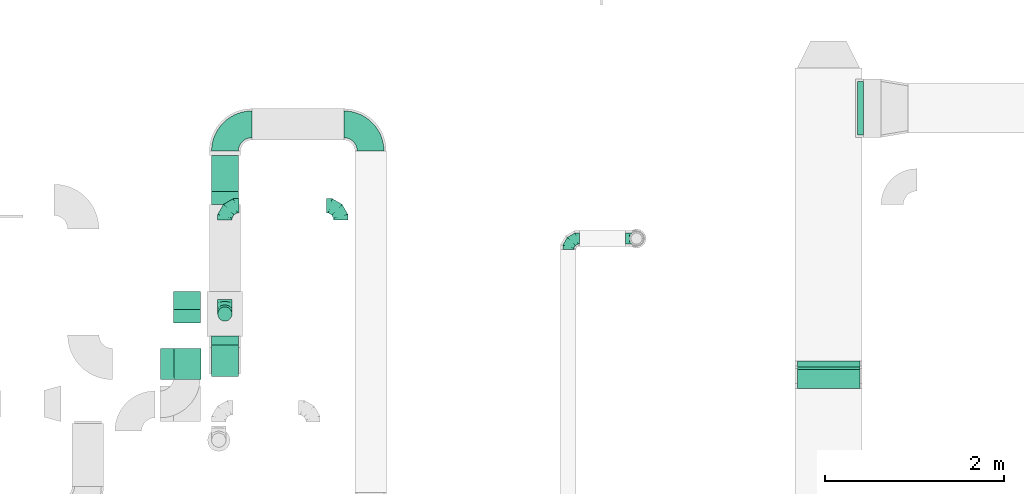
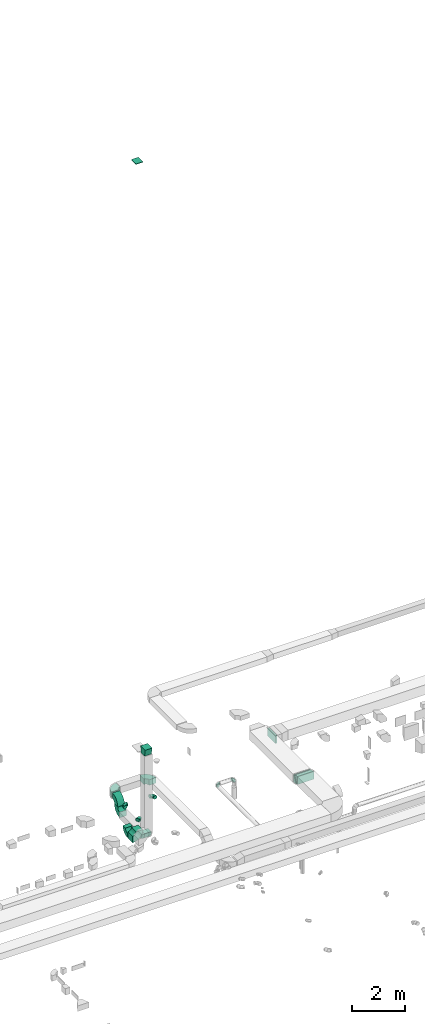
# One storey, part 46 of 97: 17 flow fittings.
"""IFC2X3 building model written with IfcOpenShell, lengths in millimetres."""

from ifc_helpers import new_model, entity, si_unit, converted_unit, derived_unit, direction, frame, frame_2d, origin, origin_2d_with_axis, place, context, subcontext, project, spatial, polyline, circle_curve, parameter, trimmed, segment, composite_curve, rectangle, outline, extrude, faceted_brep, source, transform, mapped, material, type_object, type_shapes, element, save


model = new_model("IFC2X3")

# Units and contexts
model_context = context("Model", 3, precision=0.01, world=origin(), true_north=direction((6.12303176911189e-17, 1.0)))
body_context = subcontext(model_context, "Body", "Model", "MODEL_VIEW")
ifc_project = project(units=[si_unit("LENGTHUNIT", "METRE", prefix="MILLI"), si_unit("AREAUNIT", "SQUARE_METRE"), si_unit("VOLUMEUNIT", "CUBIC_METRE"), converted_unit("PLANEANGLEUNIT", "DEGREE", entity("IfcRatioMeasure", 0.0174532925199433), si_unit("PLANEANGLEUNIT", "RADIAN"), dimensions=[0, 0, 0, 0, 0, 0, 0]), si_unit("MASSUNIT", "GRAM", prefix="KILO"), derived_unit("MASSDENSITYUNIT", [(si_unit("MASSUNIT", "GRAM", prefix="KILO"), 1), (si_unit("LENGTHUNIT", "METRE"), -3)]), derived_unit("MOMENTOFINERTIAUNIT", [(si_unit("LENGTHUNIT", "METRE"), 4)]), si_unit("TIMEUNIT", "SECOND"), si_unit("FREQUENCYUNIT", "HERTZ"), si_unit("THERMODYNAMICTEMPERATUREUNIT", "DEGREE_CELSIUS"), derived_unit("THERMALTRANSMITTANCEUNIT", [(si_unit("MASSUNIT", "GRAM", prefix="KILO"), 1), (si_unit("THERMODYNAMICTEMPERATUREUNIT", "KELVIN"), -1), (si_unit("TIMEUNIT", "SECOND"), -3)]), derived_unit("VOLUMETRICFLOWRATEUNIT", [(si_unit("LENGTHUNIT", "METRE"), 3), (si_unit("TIMEUNIT", "SECOND"), -1)]), derived_unit("MASSFLOWRATEUNIT", [(si_unit("MASSUNIT", "GRAM", prefix="KILO"), 1), (si_unit("TIMEUNIT", "SECOND"), -1)]), derived_unit("ROTATIONALFREQUENCYUNIT", [(si_unit("TIMEUNIT", "SECOND"), -1)]), si_unit("ELECTRICCURRENTUNIT", "AMPERE"), si_unit("ELECTRICVOLTAGEUNIT", "VOLT"), si_unit("POWERUNIT", "WATT"), si_unit("FORCEUNIT", "NEWTON", prefix="KILO"), si_unit("ILLUMINANCEUNIT", "LUX"), si_unit("LUMINOUSFLUXUNIT", "LUMEN"), si_unit("LUMINOUSINTENSITYUNIT", "CANDELA"), derived_unit("USERDEFINED", [(si_unit("MASSUNIT", "GRAM", prefix="KILO"), -1), (si_unit("LENGTHUNIT", "METRE"), -2), (si_unit("TIMEUNIT", "SECOND"), 3), (si_unit("LUMINOUSFLUXUNIT", "LUMEN"), 1)]), derived_unit("LINEARVELOCITYUNIT", [(si_unit("LENGTHUNIT", "METRE"), 1), (si_unit("TIMEUNIT", "SECOND"), -1)]), si_unit("PRESSUREUNIT", "PASCAL"), derived_unit("USERDEFINED", [(si_unit("LENGTHUNIT", "METRE"), -2), (si_unit("MASSUNIT", "GRAM", prefix="KILO"), 1), (si_unit("TIMEUNIT", "SECOND"), -2)]), derived_unit("LINEARFORCEUNIT", [(si_unit("MASSUNIT", "GRAM", prefix="KILO"), 1), (si_unit("LENGTHUNIT", "METRE"), 1), (si_unit("TIMEUNIT", "SECOND"), -2), (si_unit("LENGTHUNIT", "METRE"), -1)]), derived_unit("PLANARFORCEUNIT", [(si_unit("MASSUNIT", "GRAM", prefix="KILO"), 1), (si_unit("LENGTHUNIT", "METRE"), 1), (si_unit("TIMEUNIT", "SECOND"), -2), (si_unit("LENGTHUNIT", "METRE"), -2)])], contexts=[model_context])

# Site, building, storey
site_placement = place(None, origin())
site = spatial("IfcSite", under=ifc_project, at=site_placement, CompositionType="ELEMENT")
building_placement = place(site_placement, origin())
building = spatial("IfcBuilding", under=site, at=building_placement, CompositionType="ELEMENT")
storey_placement = place(building_placement, frame((0.0, 0.0, -4900.0)))
storey = spatial("IfcBuildingStorey", under=building, at=storey_placement, CompositionType="ELEMENT", Elevation=-4900.0)

# Flow fittings
ifc_material = material()
duct_fitting_type_1 = type_object("IfcDuctFittingType", PredefinedType="NOTDEFINED", material=ifc_material)
shared_shape_1 = source(origin(), body_context, "Body", "SweptSolid", [
    extrude(rectangle(XDim=65.4326874347239, YDim=600.0, at=origin_2d_with_axis()), frame((6.95, 0.0, -175.0)), (0.0, 0.0, 1.0), 350.0),
])
type_shapes(duct_fitting_type_1, [shared_shape_1])
flow_fitting_1_placement = place(storey_placement, frame((38659.51, 15349.1, 4200.0), z_axis=(0.0, 0.0, -1.0), x_axis=(1.0, 0.0, 0.0)))
element("IfcFlowFitting", 1, at=flow_fitting_1_placement, inside=storey, type_object=duct_fitting_type_1, material=ifc_material, context=body_context, shape_type="MappedRepresentation", body=[
    mapped(shared_shape_1, transform((0.0, 0.0, 0.0), scale=1.0)),
])
duct_fitting_type_2 = type_object("IfcDuctFittingType", PredefinedType="NOTDEFINED", material=ifc_material)
shared_shape_2 = source(origin(), body_context, "Body", "SweptSolid", [
    extrude(rectangle(XDim=24.9999999999999, YDim=350.0, at=origin_2d_with_axis()), frame((12.5, 0.0, -150.0)), (0.0, 0.0, 1.0), 300.0),
])
type_shapes(duct_fitting_type_2, [shared_shape_2])
flow_fitting_2_placement = place(storey_placement, frame((31140.11, 12489.49, 34965.0), z_axis=(-1.0, 0.0, 0.0), x_axis=(0.0, 0.0, 1.0)))
element("IfcFlowFitting", 2, at=flow_fitting_2_placement, inside=storey, type_object=duct_fitting_type_2, material=ifc_material, context=body_context, shape_type="MappedRepresentation", body=[
    mapped(shared_shape_2, transform((0.0, 0.0, 0.0), scale=1.0)),
])
duct_fitting_type_3 = type_object("IfcDuctFittingType", PredefinedType="NOTDEFINED", material=ifc_material)
shared_shape_3 = source(origin(), body_context, "Body", "SweptSolid", [
    extrude(outline(polyline([(-127.41, -147.96), (176.73, -147.96), (119.19, 197.28), (-168.51, 98.64), (-127.41, -147.96)])), frame((150.0, -150.0, 0.0), z_axis=(-3.32182196340705e-05, 1.0, 0.0), x_axis=(0.98639392330265, 3.27662500080578e-05, 0.164398987217013)), (3.27662500080578e-05, 5.46104166499381e-06, 1.0), 300.0),
])
type_shapes(duct_fitting_type_3, [shared_shape_3])
flow_fitting_3_placement = place(storey_placement, frame((31560.12, 12524.99, 7580.0), z_axis=(0.0, -1.0, 0.0), x_axis=(-2.94447184401029e-05, 0.0, 1.0)))
element("IfcFlowFitting", 3, at=flow_fitting_3_placement, inside=storey, type_object=duct_fitting_type_3, material=ifc_material, context=body_context, shape_type="MappedRepresentation", body=[
    mapped(shared_shape_3, transform((0.0, 0.0, 0.0), scale=1.0)),
])
duct_fitting_type_4 = type_object("IfcDuctFittingType", PredefinedType="NOTDEFINED", material=ifc_material)
shared_shape_4 = source(origin(), body_context, "Body", "Brep", [
    faceted_brep([(-160.0, 0.0, -80.0), (-160.0, -20.71, -77.27), (-160.0, -40.0, -69.28), (-160.0, -56.57, -56.57), (-160.0, -69.28, -40.0), (-160.0, -77.27, -20.71), (-160.0, -80.0, 0.0), (-160.0, -77.27, 20.71), (-160.0, -69.28, 40.0), (-160.0, -56.57, 56.57), (-160.0, -40.0, 69.28), (-160.0, -20.71, 77.27), (-160.0, 0.0, 80.0), (-160.0, 20.71, 77.27), (-160.0, 40.0, 69.28), (-160.0, 56.57, 56.57), (-160.0, 69.28, 40.0), (-160.0, 77.27, 20.71), (-160.0, 80.0, 0.0), (-160.0, 77.27, -20.71), (-160.0, 69.28, -40.0), (-160.0, 56.57, -56.57), (-160.0, 40.0, -69.28), (-160.0, 20.71, -77.27), (-122.68, 20.71, 77.27), (-127.85, 40.0, 69.28), (-117.13, 0.0, 80.0), (-132.29, 56.57, 56.57), (-137.83, 77.27, 20.71), (-138.56, 80.0, 0.0), (-135.69, 69.28, 40.0), (-135.69, 69.28, -40.0), (-132.29, 56.57, -56.57), (-137.83, 77.27, -20.71), (-122.68, 20.71, -77.27), (-117.13, 0.0, -80.0), (-127.85, 40.0, -69.28), (-111.58, -20.71, -77.27), (-106.41, -40.0, -69.28), (-101.97, -56.57, -56.57), (-98.56, -69.28, -40.0), (-96.42, -77.27, -20.71), (-95.69, -80.0, 0.0), (-96.42, -77.27, 20.71), (-98.56, -69.28, 40.0), (-101.97, -56.57, 56.57), (-106.41, -40.0, 69.28), (-111.58, -20.71, 77.27), (-58.03, 58.03, 77.27), (-72.15, 72.15, 69.28), (-42.87, 42.87, 80.0), (-84.28, 84.28, 56.57), (-93.59, 93.59, 40.0), (-99.44, 99.44, 20.71), (-101.44, 101.44, 0.0), (-99.44, 99.44, -20.71), (-93.59, 93.59, -40.0), (-84.28, 84.28, -56.57), (-58.03, 58.03, -77.27), (-42.87, 42.87, -80.0), (-72.15, 72.15, -69.28), (-27.71, 27.71, -77.27), (-13.59, 13.59, -69.28), (-1.46, 1.46, -56.57), (7.85, -7.85, -40.0), (13.7, -13.7, -20.71), (15.69, -15.69, 0.0), (13.7, -13.7, 20.71), (7.85, -7.85, 40.0), (-1.46, 1.46, 56.57), (-13.59, 13.59, 69.28), (-27.71, 27.71, 77.27), (-20.71, 122.68, 77.27), (-40.0, 127.85, 69.28), (0.0, 117.13, 80.0), (-56.57, 132.29, 56.57), (-69.28, 135.69, 40.0), (-77.27, 137.83, 20.71), (-80.0, 138.56, 0.0), (-77.27, 137.83, -20.71), (-69.28, 135.69, -40.0), (-56.57, 132.29, -56.57), (-20.71, 122.68, -77.27), (0.0, 117.13, -80.0), (-40.0, 127.85, -69.28), (20.71, 111.58, -77.27), (40.0, 106.41, -69.28), (56.57, 101.97, -56.57), (69.28, 98.56, -40.0), (77.27, 96.42, -20.71), (80.0, 95.69, 0.0), (77.27, 96.42, 20.71), (69.28, 98.56, 40.0), (56.57, 101.97, 56.57), (40.0, 106.41, 69.28), (20.71, 111.58, 77.27), (-20.71, 160.0, -77.27), (-40.0, 160.0, -69.28), (-56.57, 160.0, -56.57), (-69.28, 160.0, -40.0), (-77.27, 160.0, -20.71), (-80.0, 160.0, 0.0), (-77.27, 160.0, 20.71), (-69.28, 160.0, 40.0), (-56.57, 160.0, 56.57), (-40.0, 160.0, 69.28), (-20.71, 160.0, 77.27), (0.0, 160.0, 80.0), (20.71, 160.0, 77.27), (40.0, 160.0, 69.28), (56.57, 160.0, 56.57), (69.28, 160.0, 40.0), (77.27, 160.0, 20.71), (80.0, 160.0, 0.0), (77.27, 160.0, -20.71), (69.28, 160.0, -40.0), (56.57, 160.0, -56.57), (40.0, 160.0, -69.28), (20.71, 160.0, -77.27), (0.0, 160.0, -80.0)], [[[0, 1, 2, 3, 4, 5, 6, 7, 8, 9, 10, 11, 12, 13, 14, 15, 16, 17, 18, 19, 20, 21, 22, 23]], [[24, 25, 14, 13]], [[26, 24, 13, 12]], [[14, 25, 27, 15]], [[28, 29, 18, 17]], [[30, 28, 17, 16]], [[15, 27, 30, 16]], [[20, 31, 32, 21]], [[33, 31, 20, 19]], [[18, 29, 33, 19]], [[34, 35, 0, 23]], [[36, 34, 23, 22]], [[32, 36, 22, 21]], [[1, 0, 35, 37]], [[2, 1, 37, 38]], [[3, 2, 38, 39]], [[5, 4, 40, 41]], [[6, 5, 41, 42]], [[39, 40, 4, 3]], [[6, 42, 43, 7]], [[7, 43, 44, 8]], [[8, 44, 45, 9]], [[9, 45, 46, 10]], [[10, 46, 47, 11]], [[26, 12, 11, 47]], [[48, 49, 25, 24]], [[50, 48, 24, 26]], [[27, 25, 49, 51]], [[52, 53, 28, 30]], [[51, 52, 30, 27]], [[29, 28, 53, 54]], [[55, 56, 31, 33]], [[54, 55, 33, 29]], [[32, 31, 56, 57]], [[58, 59, 35, 34]], [[60, 58, 34, 36]], [[57, 60, 36, 32]], [[37, 35, 59, 61]], [[38, 37, 61, 62]], [[39, 38, 62, 63]], [[41, 40, 64, 65]], [[42, 41, 65, 66]], [[63, 64, 40, 39]], [[43, 42, 66, 67]], [[44, 43, 67, 68]], [[68, 69, 45, 44]], [[46, 45, 69, 70]], [[47, 46, 70, 71]], [[26, 47, 71, 50]], [[72, 73, 49, 48]], [[74, 72, 48, 50]], [[51, 49, 73, 75]], [[76, 77, 53, 52]], [[75, 76, 52, 51]], [[54, 53, 77, 78]], [[79, 80, 56, 55]], [[78, 79, 55, 54]], [[57, 56, 80, 81]], [[82, 83, 59, 58]], [[84, 82, 58, 60]], [[81, 84, 60, 57]], [[61, 59, 83, 85]], [[62, 61, 85, 86]], [[63, 62, 86, 87]], [[65, 64, 88, 89]], [[66, 65, 89, 90]], [[87, 88, 64, 63]], [[67, 66, 90, 91]], [[68, 67, 91, 92]], [[92, 93, 69, 68]], [[70, 69, 93, 94]], [[71, 70, 94, 95]], [[50, 71, 95, 74]], [[96, 97, 98, 99, 100, 101, 102, 103, 104, 105, 106, 107, 108, 109, 110, 111, 112, 113, 114, 115, 116, 117, 118, 119]], [[72, 74, 107, 106]], [[73, 72, 106, 105]], [[75, 73, 105, 104]], [[77, 76, 103, 102]], [[78, 77, 102, 101]], [[75, 104, 103, 76]], [[78, 101, 100, 79]], [[79, 100, 99, 80]], [[80, 99, 98, 81]], [[84, 97, 96, 82]], [[82, 96, 119, 83]], [[84, 81, 98, 97]], [[118, 117, 86, 85]], [[119, 118, 85, 83]], [[116, 87, 86, 117]], [[88, 115, 114, 89]], [[89, 114, 113, 90]], [[115, 88, 87, 116]], [[112, 111, 92, 91]], [[113, 112, 91, 90]], [[111, 110, 93, 92]], [[95, 94, 109, 108]], [[74, 95, 108, 107]], [[110, 109, 94, 93]]]),
])
type_shapes(duct_fitting_type_4, [shared_shape_4])
for number, where, z_axis, x_axis in (
    (4, (31558.92, 13048.57, 4150.0), (-1.0, 0.0, 0.0), (0.0, -1.0, 0.0)),
    (5, (31558.92, 14258.43, 4150.0), (0.0, 0.0, 1.0), (-1.0, 0.0, 0.0)),
    (6, (32854.47, 14258.43, 4150.0), (0.0, 0.0, 1.0), (0.0, 1.0, 0.0)),
):
    element("IfcFlowFitting", number, at=place(storey_placement, frame(where, z_axis=z_axis, x_axis=x_axis)), inside=storey, type_object=duct_fitting_type_4, material=ifc_material, context=body_context, shape_type="MappedRepresentation", body=[
        mapped(shared_shape_4, transform((0.0, 0.0, 0.0), scale=1.0)),
    ])
duct_fitting_type_5 = type_object("IfcDuctFittingType", PredefinedType="NOTDEFINED", material=ifc_material)
shared_shape_5 = source(origin(), body_context, "Body", "Brep", [
    faceted_brep([(-125.0, 0.0, -62.5), (-125.0, -16.18, -60.37), (-125.0, -31.25, -54.13), (-125.0, -44.19, -44.19), (-125.0, -54.13, -31.25), (-125.0, -60.37, -16.18), (-125.0, -62.5, 0.0), (-125.0, -60.37, 16.18), (-125.0, -54.13, 31.25), (-125.0, -44.19, 44.19), (-125.0, -31.25, 54.13), (-125.0, -16.18, 60.37), (-125.0, 0.0, 62.5), (-125.0, 16.18, 60.37), (-125.0, 31.25, 54.13), (-125.0, 44.19, 44.19), (-125.0, 54.13, 31.25), (-125.0, 60.37, 16.18), (-125.0, 62.5, 0.0), (-125.0, 60.37, -16.18), (-125.0, 54.13, -31.25), (-125.0, 44.19, -44.19), (-125.0, 31.25, -54.13), (-125.0, 16.18, -60.37), (-95.84, 16.18, 60.37), (-99.88, 31.25, 54.13), (-91.51, 0.0, 62.5), (-103.35, 44.19, 44.19), (-107.68, 60.37, 16.18), (-108.25, 62.5, 0.0), (-106.01, 54.13, 31.25), (-106.01, 54.13, -31.25), (-103.35, 44.19, -44.19), (-107.68, 60.37, -16.18), (-95.84, 16.18, -60.37), (-91.51, 0.0, -62.5), (-99.88, 31.25, -54.13), (-87.17, -16.18, -60.37), (-83.13, -31.25, -54.13), (-79.66, -44.19, -44.19), (-77.0, -54.13, -31.25), (-75.33, -60.37, -16.18), (-74.76, -62.5, 0.0), (-75.33, -60.37, 16.18), (-77.0, -54.13, 31.25), (-79.66, -44.19, 44.19), (-83.13, -31.25, 54.13), (-87.17, -16.18, 60.37), (-45.34, 45.34, 60.37), (-56.37, 56.37, 54.13), (-33.49, 33.49, 62.5), (-65.85, 65.85, 44.19), (-73.12, 73.12, 31.25), (-77.69, 77.69, 16.18), (-79.25, 79.25, 0.0), (-77.69, 77.69, -16.18), (-73.12, 73.12, -31.25), (-65.85, 65.85, -44.19), (-45.34, 45.34, -60.37), (-33.49, 33.49, -62.5), (-56.37, 56.37, -54.13), (-21.65, 21.65, -60.37), (-10.62, 10.62, -54.13), (-1.14, 1.14, -44.19), (6.13, -6.13, -31.25), (10.7, -10.7, -16.18), (12.26, -12.26, 0.0), (10.7, -10.7, 16.18), (6.13, -6.13, 31.25), (-1.14, 1.14, 44.19), (-10.62, 10.62, 54.13), (-21.65, 21.65, 60.37), (-16.18, 95.84, 60.37), (-31.25, 99.88, 54.13), (0.0, 91.51, 62.5), (-44.19, 103.35, 44.19), (-54.13, 106.01, 31.25), (-60.37, 107.68, 16.18), (-62.5, 108.25, 0.0), (-60.37, 107.68, -16.18), (-54.13, 106.01, -31.25), (-44.19, 103.35, -44.19), (-16.18, 95.84, -60.37), (0.0, 91.51, -62.5), (-31.25, 99.88, -54.13), (16.18, 87.17, -60.37), (31.25, 83.13, -54.13), (44.19, 79.66, -44.19), (54.13, 77.0, -31.25), (60.37, 75.33, -16.18), (62.5, 74.76, 0.0), (60.37, 75.33, 16.18), (54.13, 77.0, 31.25), (44.19, 79.66, 44.19), (31.25, 83.13, 54.13), (16.18, 87.17, 60.37), (-16.18, 125.0, -60.37), (-31.25, 125.0, -54.13), (-44.19, 125.0, -44.19), (-54.13, 125.0, -31.25), (-60.37, 125.0, -16.18), (-62.5, 125.0, 0.0), (-60.37, 125.0, 16.18), (-54.13, 125.0, 31.25), (-44.19, 125.0, 44.19), (-31.25, 125.0, 54.13), (-16.18, 125.0, 60.37), (0.0, 125.0, 62.5), (16.18, 125.0, 60.37), (31.25, 125.0, 54.13), (44.19, 125.0, 44.19), (54.13, 125.0, 31.25), (60.37, 125.0, 16.18), (62.5, 125.0, 0.0), (60.37, 125.0, -16.18), (54.13, 125.0, -31.25), (44.19, 125.0, -44.19), (31.25, 125.0, -54.13), (16.18, 125.0, -60.37), (0.0, 125.0, -62.5)], [[[0, 1, 2, 3, 4, 5, 6, 7, 8, 9, 10, 11, 12, 13, 14, 15, 16, 17, 18, 19, 20, 21, 22, 23]], [[24, 25, 14, 13]], [[26, 24, 13, 12]], [[14, 25, 27, 15]], [[28, 29, 18, 17]], [[30, 28, 17, 16]], [[15, 27, 30, 16]], [[20, 31, 32, 21]], [[33, 31, 20, 19]], [[18, 29, 33, 19]], [[34, 35, 0, 23]], [[36, 34, 23, 22]], [[21, 32, 36, 22]], [[1, 0, 35, 37]], [[2, 1, 37, 38]], [[38, 39, 3, 2]], [[5, 4, 40, 41]], [[6, 5, 41, 42]], [[39, 40, 4, 3]], [[6, 42, 43, 7]], [[7, 43, 44, 8]], [[45, 9, 8, 44]], [[9, 45, 46, 10]], [[10, 46, 47, 11]], [[26, 12, 11, 47]], [[48, 49, 25, 24]], [[50, 48, 24, 26]], [[27, 25, 49, 51]], [[52, 53, 28, 30]], [[51, 52, 30, 27]], [[29, 28, 53, 54]], [[55, 56, 31, 33]], [[54, 55, 33, 29]], [[57, 32, 31, 56]], [[58, 59, 35, 34]], [[60, 58, 34, 36]], [[57, 60, 36, 32]], [[37, 35, 59, 61]], [[38, 37, 61, 62]], [[39, 38, 62, 63]], [[41, 40, 64, 65]], [[42, 41, 65, 66]], [[63, 64, 40, 39]], [[43, 42, 66, 67]], [[44, 43, 67, 68]], [[68, 69, 45, 44]], [[46, 45, 69, 70]], [[47, 46, 70, 71]], [[26, 47, 71, 50]], [[72, 73, 49, 48]], [[74, 72, 48, 50]], [[51, 49, 73, 75]], [[76, 77, 53, 52]], [[75, 76, 52, 51]], [[54, 53, 77, 78]], [[79, 80, 56, 55]], [[78, 79, 55, 54]], [[81, 57, 56, 80]], [[82, 83, 59, 58]], [[84, 82, 58, 60]], [[81, 84, 60, 57]], [[61, 59, 83, 85]], [[62, 61, 85, 86]], [[63, 62, 86, 87]], [[65, 64, 88, 89]], [[66, 65, 89, 90]], [[87, 88, 64, 63]], [[67, 66, 90, 91]], [[68, 67, 91, 92]], [[92, 93, 69, 68]], [[70, 69, 93, 94]], [[71, 70, 94, 95]], [[50, 71, 95, 74]], [[96, 97, 98, 99, 100, 101, 102, 103, 104, 105, 106, 107, 108, 109, 110, 111, 112, 113, 114, 115, 116, 117, 118, 119]], [[72, 74, 107, 106]], [[73, 72, 106, 105]], [[75, 73, 105, 104]], [[77, 76, 103, 102]], [[78, 77, 102, 101]], [[75, 104, 103, 76]], [[78, 101, 100, 79]], [[79, 100, 99, 80]], [[80, 99, 98, 81]], [[96, 119, 83, 82]], [[97, 96, 82, 84]], [[84, 81, 98, 97]], [[83, 119, 118, 85]], [[85, 118, 117, 86]], [[116, 87, 86, 117]], [[88, 115, 114, 89]], [[89, 114, 113, 90]], [[115, 88, 87, 116]], [[91, 90, 113, 112]], [[92, 91, 112, 111]], [[111, 110, 93, 92]], [[95, 94, 109, 108]], [[74, 95, 108, 107]], [[110, 109, 94, 93]]]),
])
type_shapes(duct_fitting_type_5, [shared_shape_5])
for number, where, z_axis, x_axis in (
    (7, (35399.64, 13892.11, 3980.0), (0.0, 0.0, 1.0), (-1.0, 0.0, 0.0)),
    (8, (36161.96, 13892.11, 3980.0), (0.0, 1.0, 0.0), (1.0, 0.0, 0.0)),
):
    element("IfcFlowFitting", number, at=place(storey_placement, frame(where, z_axis=z_axis, x_axis=x_axis)), inside=storey, type_object=duct_fitting_type_5, material=ifc_material, context=body_context, shape_type="MappedRepresentation", body=[
        mapped(shared_shape_5, transform((0.0, 0.0, 0.0), scale=1.0)),
    ])
duct_fitting_type_6 = type_object("IfcDuctFittingType", PredefinedType="NOTDEFINED", material=ifc_material)
shared_shape_6 = source(origin(), body_context, "Body", "SweptSolid", [
    extrude(outline(composite_curve([segment(polyline([(-190.22, -68.68), (159.78, -68.68)]), True, "CONTINUOUS"), segment(trimmed(circle_curve(frame_2d((309.78, -68.68), x_axis=(-0.906307787036651, 0.422618261740699)), 150.0), [parameter(0.0)], [parameter(24.9999999999999)], True, "PARAMETER"), False, "CONTINUOUS"), segment(polyline([(173.83, -5.28), (-143.38, 142.63)]), True, "CONTINUOUS"), segment(trimmed(circle_curve(frame_2d((309.78, -68.68), x_axis=(-0.906307787036651, 0.422618261740699)), 500.0), [parameter(0.0)], [parameter(24.9999999999999)], True, "PARAMETER"), True, "CONTINUOUS")], self_intersect=False)), frame((-3.38, 15.22, -350.0), z_axis=(0.0, 0.0, 1.0), x_axis=(-0.422618261740699, 0.90630778703665, 0.0)), (0.0, 0.0, 1.0), 700.0),
])
type_shapes(duct_fitting_type_6, [shared_shape_6])
for number, where, z_axis, x_axis in (
    (9, (38309.51, 12287.73, 4275.0), (-1.0, 0.0, 0.0), (0.0, 1.0, 0.0)),
    (10, (38309.51, 12448.57, 4200.0), (1.0, 0.0, 0.0), (0.0, 0.906307787036485, -0.422618261741052)),
):
    element("IfcFlowFitting", number, at=place(storey_placement, frame(where, z_axis=z_axis, x_axis=x_axis)), inside=storey, type_object=duct_fitting_type_6, material=ifc_material, context=body_context, shape_type="MappedRepresentation", body=[
        mapped(shared_shape_6, transform((0.0, 0.0, 0.0), scale=1.0)),
    ])
duct_fitting_type_7 = type_object("IfcDuctFittingType", PredefinedType="NOTDEFINED", material=ifc_material)
shared_shape_7 = source(origin(), body_context, "Body", "SweptSolid", [
    extrude(outline(composite_curve([segment(polyline([(-300.0, -150.0), (0.0, -150.0)]), True, "CONTINUOUS"), segment(trimmed(circle_curve(frame_2d((150.0, -150.0), x_axis=(0.0, 1.0)), 150.0), [parameter(0.0)], [parameter(90.0)], True, "PARAMETER"), False, "CONTINUOUS"), segment(polyline([(150.0, 0.0), (150.0, 300.0)]), True, "CONTINUOUS"), segment(trimmed(circle_curve(frame_2d((150.0, -150.0), x_axis=(0.0, 1.0)), 450.0), [parameter(0.0)], [parameter(90.0000000000001)], True, "PARAMETER"), True, "CONTINUOUS")], self_intersect=False)), frame((-150.0, 150.0, -125.0), z_axis=(0.0, 0.0, 1.0), x_axis=(-1.0, 0.0, 0.0)), (0.0, 0.0, 1.0), 250.0),
])
type_shapes(duct_fitting_type_7, [shared_shape_7])
for number, where, z_axis, x_axis in (
    (11, (33188.7, 15169.18, 4300.0), (-1.53428663483707e-08, 0.0, 1.0), (0.0, 1.0, 0.0)),
    (12, (31560.22, 15169.18, 4300.0), (-1.53428668330859e-08, 0.0, 1.0), (-1.0, 0.0, -1.53428668330859e-08)),
):
    element("IfcFlowFitting", number, at=place(storey_placement, frame(where, z_axis=z_axis, x_axis=x_axis)), inside=storey, type_object=duct_fitting_type_7, material=ifc_material, context=body_context, shape_type="MappedRepresentation", body=[
        mapped(shared_shape_7, transform((0.0, 0.0, 0.0), scale=1.0)),
    ])
duct_fitting_type_8 = type_object("IfcDuctFittingType", PredefinedType="NOTDEFINED", material=ifc_material)
shared_shape_8 = source(origin(), body_context, "Body", "SweptSolid", [
    extrude(outline(composite_curve([segment(polyline([(-225.0, -125.0), (-25.0, -125.0)]), True, "CONTINUOUS"), segment(trimmed(circle_curve(frame_2d((125.0, -125.0), x_axis=(0.0, 1.0)), 150.0), [parameter(0.0)], [parameter(90.0)], True, "PARAMETER"), False, "CONTINUOUS"), segment(polyline([(125.0, 25.0), (125.0, 225.0)]), True, "CONTINUOUS"), segment(trimmed(circle_curve(frame_2d((125.0, -125.0), x_axis=(0.0, 1.0)), 350.0), [parameter(0.0)], [parameter(90.0)], True, "PARAMETER"), True, "CONTINUOUS")], self_intersect=False)), frame((-125.0, 125.0, -150.0), z_axis=(0.0, 0.0, 1.0), x_axis=(-1.0, 0.0, 0.0)), (0.0, 0.0, 1.0), 300.0),
])
type_shapes(duct_fitting_type_8, [shared_shape_8])
flow_fitting_4_placement = place(storey_placement, frame((31134.29, 13199.88, 3750.0), z_axis=(0.999999981765208, 0.0, -0.000190970110692879), x_axis=(0.0, 1.0, 0.0)))
element("IfcFlowFitting", 13, at=flow_fitting_4_placement, inside=storey, type_object=duct_fitting_type_8, material=ifc_material, context=body_context, shape_type="MappedRepresentation", body=[
    mapped(shared_shape_8, transform((0.0, 0.0, 0.0), scale=1.0)),
])
duct_fitting_type_9 = type_object("IfcDuctFittingType", PredefinedType="NOTDEFINED", material=ifc_material)
shared_shape_9 = source(origin(), body_context, "Body", "SweptSolid", [
    extrude(outline(composite_curve([segment(polyline([(-300.0, -150.0), (0.0, -150.0)]), True, "CONTINUOUS"), segment(trimmed(circle_curve(frame_2d((150.0, -150.0), x_axis=(0.0, 1.0)), 150.0), [parameter(0.0)], [parameter(90.0)], True, "PARAMETER"), False, "CONTINUOUS"), segment(polyline([(150.0, 0.0), (150.0, 300.0)]), True, "CONTINUOUS"), segment(trimmed(circle_curve(frame_2d((150.0, -150.0), x_axis=(0.0, 1.0)), 450.0), [parameter(0.0)], [parameter(90.0)], True, "PARAMETER"), True, "CONTINUOUS")], self_intersect=False)), frame((-150.0, 150.0, -175.0), z_axis=(0.0, 0.0, 1.0), x_axis=(-1.0, 0.0, 0.0)), (0.0, 0.0, 1.0), 350.0),
])
type_shapes(duct_fitting_type_9, [shared_shape_9])
flow_fitting_5_placement = place(storey_placement, frame((31140.11, 12489.49, 4000.0), z_axis=(0.0, -1.0, 0.0), x_axis=(1.0, 0.0, 0.0)))
element("IfcFlowFitting", 14, at=flow_fitting_5_placement, inside=storey, type_object=duct_fitting_type_9, material=ifc_material, context=body_context, shape_type="MappedRepresentation", body=[
    mapped(shared_shape_9, transform((0.0, 0.0, 0.0), scale=1.0)),
])
duct_fitting_type_10 = type_object("IfcDuctFittingType", PredefinedType="NOTDEFINED", material=ifc_material)
shared_shape_10 = source(origin(), body_context, "Body", "SweptSolid", [
    extrude(outline(composite_curve([segment(polyline([(-262.5, -137.5), (-12.5, -137.5)]), True, "CONTINUOUS"), segment(trimmed(circle_curve(frame_2d((137.5, -137.5), x_axis=(0.0, 1.0)), 150.0), [parameter(0.0)], [parameter(90.0000000000001)], True, "PARAMETER"), False, "CONTINUOUS"), segment(polyline([(137.5, 12.5), (137.5, 262.5)]), True, "CONTINUOUS"), segment(trimmed(circle_curve(frame_2d((137.5, -137.5), x_axis=(0.0, 1.0)), 400.0), [parameter(0.0)], [parameter(90.0000000000001)], True, "PARAMETER"), True, "CONTINUOUS")], self_intersect=False)), frame((-137.5, 137.5, -150.0), z_axis=(0.0, 0.0, 1.0), x_axis=(-1.0, 0.0, 0.0)), (0.0, 0.0, 1.0), 300.0),
])
type_shapes(duct_fitting_type_10, [shared_shape_10])
flow_fitting_6_placement = place(storey_placement, frame((31560.22, 14544.99, 4300.0), z_axis=(-1.0, 0.0, 0.0), x_axis=(0.0, 0.0, 1.0)))
element("IfcFlowFitting", 15, at=flow_fitting_6_placement, inside=storey, type_object=duct_fitting_type_10, material=ifc_material, context=body_context, shape_type="MappedRepresentation", body=[
    mapped(shared_shape_10, transform((0.0, 0.0, 0.0), scale=1.0)),
])
duct_fitting_type_11 = type_object("IfcDuctFittingType", PredefinedType="NOTDEFINED", material=ifc_material)
shared_shape_11 = source(origin(), body_context, "Body", "SweptSolid", [
    extrude(outline(composite_curve([segment(polyline([(-262.5, -137.5), (-12.5, -137.5)]), True, "CONTINUOUS"), segment(trimmed(circle_curve(frame_2d((137.5, -137.5), x_axis=(-1.20820118354459e-08, 1.0)), 150.0), [parameter(0.0)], [parameter(89.9999993077522)], True, "PARAMETER"), False, "CONTINUOUS"), segment(polyline([(137.5, 12.5), (137.5, 262.5)]), True, "CONTINUOUS"), segment(trimmed(circle_curve(frame_2d((137.5, -137.5), x_axis=(-1.20820118354459e-08, 1.0)), 400.0), [parameter(0.0)], [parameter(89.9999993077522)], True, "PARAMETER"), True, "CONTINUOUS")], self_intersect=False)), frame((-137.5, 137.5, -150.0), z_axis=(0.0, 0.0, 1.0), x_axis=(-1.0, 1.20820058022275e-08, 0.0)), (0.0, 0.0, 1.0), 300.0),
])
type_shapes(duct_fitting_type_11, [shared_shape_11])
flow_fitting_7_placement = place(storey_placement, frame((31560.23, 12524.99, 3740.0), z_axis=(1.0, 0.0, 2.94447184401025e-05), x_axis=(2.94447184401025e-05, 0.0, -1.0)))
element("IfcFlowFitting", 16, at=flow_fitting_7_placement, inside=storey, type_object=duct_fitting_type_11, material=ifc_material, context=body_context, shape_type="MappedRepresentation", body=[
    mapped(shared_shape_11, transform((0.0, 0.0, 0.0), scale=1.0)),
])
duct_fitting_type_12 = type_object("IfcDuctFittingType", PredefinedType="NOTDEFINED", material=ifc_material)
shared_shape_12 = source(origin(), body_context, "Body", "SweptSolid", [
    extrude(outline(composite_curve([segment(polyline([(-262.5, -137.5), (-12.5, -137.5)]), True, "CONTINUOUS"), segment(trimmed(circle_curve(frame_2d((137.5, -137.5), x_axis=(1.20820118354459e-08, 1.0)), 150.0), [parameter(0.0)], [parameter(90.0000006922477)], True, "PARAMETER"), False, "CONTINUOUS"), segment(polyline([(137.5, 12.5), (137.5, 262.5)]), True, "CONTINUOUS"), segment(trimmed(circle_curve(frame_2d((137.5, -137.5), x_axis=(1.20820118354459e-08, 1.0)), 400.0), [parameter(0.0)], [parameter(90.0000006922478)], True, "PARAMETER"), True, "CONTINUOUS")], self_intersect=False)), frame((-137.5, 137.5, -150.0), z_axis=(0.0, 0.0, 1.0), x_axis=(-1.0, -1.20820012000422e-08, 0.0)), (0.0, 0.0, 1.0), 300.0),
])
type_shapes(duct_fitting_type_12, [shared_shape_12])
flow_fitting_8_placement = place(storey_placement, frame((31560.22, 14544.99, 3740.0), z_axis=(1.0, 5.1739919877206e-06, 0.0), x_axis=(-5.1739919877206e-06, 1.0, -1.20820014025661e-08)))
element("IfcFlowFitting", 17, at=flow_fitting_8_placement, inside=storey, type_object=duct_fitting_type_12, material=ifc_material, context=body_context, shape_type="MappedRepresentation", body=[
    mapped(shared_shape_12, transform((0.0, 0.0, 0.0), scale=1.0)),
])

save(model, "model.ifc")
